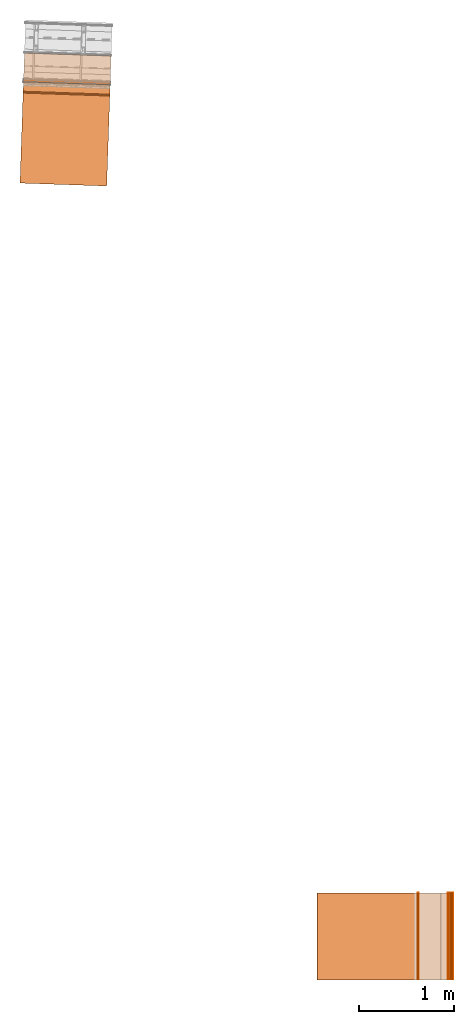
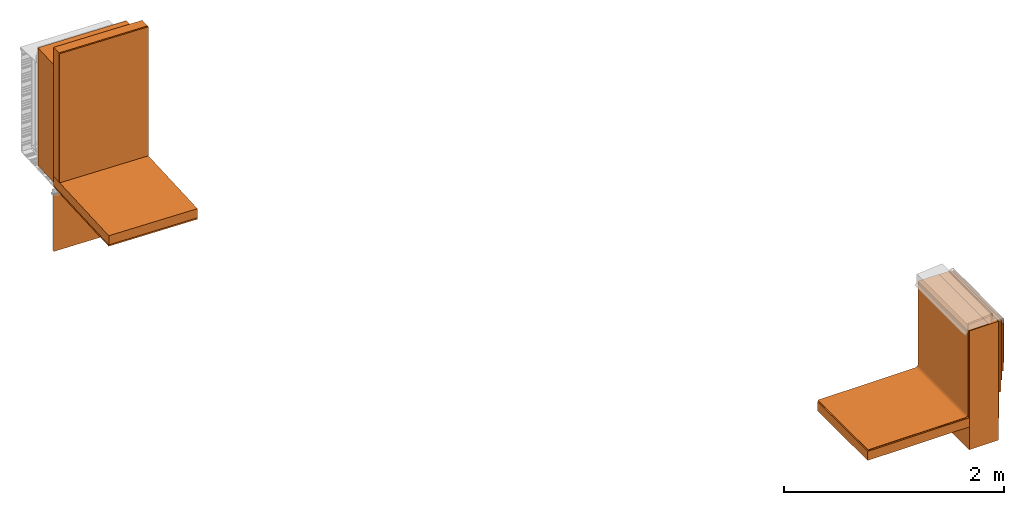
# One storey, part 1 of 6: 16 proxies.
"""IFC2X3 building model written with IfcOpenShell, lengths in feet."""

from ifc_helpers import new_model, entity, si_unit, converted_unit, derived_unit, direction, frame, frame_2d, origin, origin_2d_with_axis, place, context, subcontext, project, spatial, polyline, circle_curve, parameter, trimmed, segment, composite_curve, rectangle, outline, extrude, source, transform, mapped, material, type_object, type_shapes, element, save


model = new_model("IFC2X3")

# Units and contexts
model_context = context("Model", 3, precision=0.0001, world=origin(), true_north=direction((6.12303176911189e-17, 1.0)))
context_of_model = context(None, 3, precision=0.0001, world=origin(), true_north=direction((6.12303176911189e-17, 1.0)))
body_context = subcontext(model_context, "Body", "Model", "MODEL_VIEW")
ifc_project = project(units=[converted_unit("LENGTHUNIT", "FOOT", entity("IfcRatioMeasure", 0.3048), si_unit("LENGTHUNIT", "METRE"), dimensions=[1, 0, 0, 0, 0, 0, 0]), converted_unit("AREAUNIT", "SQUARE FOOT", entity("IfcRatioMeasure", 0.09290304), si_unit("AREAUNIT", "SQUARE_METRE"), dimensions=[2, 0, 0, 0, 0, 0, 0]), si_unit("VOLUMEUNIT", "CUBIC_METRE"), converted_unit("PLANEANGLEUNIT", "DEGREE", entity("IfcRatioMeasure", 0.0174532925199433), si_unit("PLANEANGLEUNIT", "RADIAN"), dimensions=[0, 0, 0, 0, 0, 0, 0]), si_unit("MASSUNIT", "GRAM", prefix="KILO"), derived_unit("MASSDENSITYUNIT", [(si_unit("MASSUNIT", "GRAM", prefix="KILO"), 1), (si_unit("LENGTHUNIT", "METRE"), -3)]), si_unit("TIMEUNIT", "SECOND"), si_unit("FREQUENCYUNIT", "HERTZ"), si_unit("THERMODYNAMICTEMPERATUREUNIT", "DEGREE_CELSIUS"), derived_unit("THERMALTRANSMITTANCEUNIT", [(si_unit("MASSUNIT", "GRAM", prefix="KILO"), 1), (si_unit("THERMODYNAMICTEMPERATUREUNIT", "KELVIN"), -1), (si_unit("TIMEUNIT", "SECOND"), -3)]), derived_unit("VOLUMETRICFLOWRATEUNIT", [(si_unit("LENGTHUNIT", "METRE"), 3), (si_unit("TIMEUNIT", "SECOND"), -1)]), si_unit("ELECTRICCURRENTUNIT", "AMPERE"), si_unit("ELECTRICVOLTAGEUNIT", "VOLT"), si_unit("POWERUNIT", "WATT"), si_unit("FORCEUNIT", "NEWTON"), si_unit("ILLUMINANCEUNIT", "LUX"), si_unit("LUMINOUSFLUXUNIT", "LUMEN"), si_unit("LUMINOUSINTENSITYUNIT", "CANDELA"), derived_unit("USERDEFINED", [(si_unit("MASSUNIT", "GRAM", prefix="KILO"), -1), (si_unit("LENGTHUNIT", "METRE"), -2), (si_unit("TIMEUNIT", "SECOND"), 3), (si_unit("LUMINOUSFLUXUNIT", "LUMEN"), 1)]), derived_unit("LINEARVELOCITYUNIT", [(si_unit("LENGTHUNIT", "METRE"), 1), (si_unit("TIMEUNIT", "SECOND"), -1)]), si_unit("PRESSUREUNIT", "PASCAL"), derived_unit("USERDEFINED", [(si_unit("LENGTHUNIT", "METRE"), -2), (si_unit("MASSUNIT", "GRAM", prefix="KILO"), 1), (si_unit("TIMEUNIT", "SECOND"), -2)])], contexts=[model_context, context_of_model])

# Site, building, storey
site_placement = place(None, origin())
site = spatial("IfcSite", under=ifc_project, at=site_placement, CompositionType="ELEMENT")
building_placement = place(site_placement, origin())
building = spatial("IfcBuilding", under=site, at=building_placement, CompositionType="ELEMENT")
storey_placement = place(building_placement, origin())
storey = spatial("IfcBuildingStorey", under=building, at=storey_placement, Name="Level 1", CompositionType="ELEMENT", Elevation=0.0)

# Proxies
ifc_material_1 = material()
building_element_proxy_type_1 = type_object("IfcBuildingElementProxyType", Name="Rigid insulation 002:Rigid insulation 002", PredefinedType="NOTDEFINED", material=ifc_material_1)
shared_shape_1 = source(origin(), body_context, "Body", "SweptSolid", [
    extrude(rectangle(XDim=3.50495130620078, YDim=2.99999999999999, at=frame_2d((0.0, 7.105427357601e-15), x_axis=(1.0, 0.0))), frame((121.624397761532, -80.1652000961286, 15.0), z_axis=(0.0, 0.0, 1.0), x_axis=(-1.0, 0.0, 0.0)), (0.0, 0.0, 1.0), 0.333333333333337),
])
type_shapes(building_element_proxy_type_1, [shared_shape_1])
proxy_1_placement = place(storey_placement, origin())
element("IfcBuildingElementProxy", 1, at=proxy_1_placement, inside=storey, type_object=building_element_proxy_type_1, material=ifc_material_1, context=body_context, shape_type="MappedRepresentation", body=[
    mapped(shared_shape_1, transform((0.0, 0.0, 0.0), scale=1.0)),
])
ifc_material_2 = material(Name="_EXISTING CAST-IN-PLACE CONCRETE")
building_element_proxy_type_2 = type_object("IfcBuildingElementProxyType", Name="Concrete wall 002:Concrete wall 002", PredefinedType="NOTDEFINED", material=ifc_material_2)
shared_shape_2 = source(origin(), body_context, "Body", "SweptSolid", [
    extrude(rectangle(XDim=0.999999999999972, YDim=2.99999999999999, at=frame_2d((1.4210854715202e-14, 7.105427357601e-15), x_axis=(1.0, 0.0))), frame((123.876873414633, -80.1652000961286, 14.1666666666667), z_axis=(0.0, 0.0, 1.0), x_axis=(-1.0, 0.0, 0.0)), (0.0, 0.0, 1.0), 4.33333333333333),
])
type_shapes(building_element_proxy_type_2, [shared_shape_2])
proxy_2_placement = place(storey_placement, origin())
element("IfcBuildingElementProxy", 2, at=proxy_2_placement, inside=storey, type_object=building_element_proxy_type_2, material=ifc_material_2, ObjectType="Concrete wall 002 : Concrete wall 002:Concrete wall 002", context=body_context, shape_type="MappedRepresentation", body=[
    mapped(shared_shape_2, transform((0.0, 0.0, 0.0), scale=1.0)),
])
ifc_material_3 = material(Name="IMPERMEABLE WRB MEMBRANE")
building_element_proxy_type_3 = type_object("IfcBuildingElementProxyType", Name="WRB Membrane 002:WRB Membrane 002", PredefinedType="NOTDEFINED", material=ifc_material_3)
shared_shape_3 = source(origin(), body_context, "Body", "SweptSolid", [
    extrude(rectangle(XDim=0.0208333335301916, YDim=3.0, at=origin_2d_with_axis()), frame((124.491456747933, -80.1652000961286, 16.3258133535433), z_axis=(0.0, 0.0, 1.0), x_axis=(-1.0, 0.0, 0.0)), (0.0, 0.0, 1.0), 2.17418664645669),
])
type_shapes(building_element_proxy_type_3, [shared_shape_3])
proxy_3_placement = place(storey_placement, origin())
element("IfcBuildingElementProxy", 3, at=proxy_3_placement, inside=storey, type_object=building_element_proxy_type_3, material=ifc_material_3, context=body_context, shape_type="MappedRepresentation", body=[
    mapped(shared_shape_3, transform((0.0, 0.0, 0.0), scale=1.0)),
])
building_element_proxy_type_4 = type_object("IfcBuildingElementProxyType", Name="Cement bond coat 002:Cement bond coat 002", PredefinedType="NOTDEFINED", material=ifc_material_3)
shared_shape_4 = source(origin(), body_context, "Body", "SweptSolid", [
    extrude(rectangle(XDim=0.0520833333333144, YDim=2.99999999999999, at=frame_2d((0.0, 7.105427357601e-15), x_axis=(1.0, 0.0))), frame((124.527915081496, -80.1652000961286, 16.6369885221785), z_axis=(0.0, 0.0, 1.0), x_axis=(-1.0, 0.0, 0.0)), (0.0, 0.0, 1.0), 1.7338879536868),
])
type_shapes(building_element_proxy_type_4, [shared_shape_4])
proxy_4_placement = place(storey_placement, origin())
element("IfcBuildingElementProxy", 4, at=proxy_4_placement, inside=storey, type_object=building_element_proxy_type_4, material=ifc_material_3, context=body_context, shape_type="MappedRepresentation", body=[
    mapped(shared_shape_4, transform((0.0, 0.0, 0.0), scale=1.0)),
])
ifc_material_4 = material(Name="PRESSURE TREATED WOOD BLOCKING - SIZE AS")
building_element_proxy_type_5 = type_object("IfcBuildingElementProxyType", Name="TPO Membrane 002:TPO Membrane 002", PredefinedType="NOTDEFINED", material=ifc_material_4)
shared_shape_5 = source(origin(), body_context, "Body", "SweptSolid", [
    extrude(outline(composite_curve([segment(polyline([(-1.27708333333181, -2.88937771162654), (-1.26666666666515, -2.88937771162654)]), True, "CONTINUOUS"), segment(polyline([(-1.26666666666515, -2.88937771162654), (-1.26666666666515, 0.469740261240503)]), True, "CONTINUOUS"), segment(trimmed(circle_curve(frame_2d((-1.17291666666664, 0.469740261240503), x_axis=(0.0, 1.0)), 0.0937499999969816), [parameter(6.18808718825542e-10)], [parameter(90.0000000000001)], True, "PARAMETER"), False, "CONTINUOUS"), segment(polyline([(-1.17291666666765, 0.56349026123749), (1.8635416666649, 0.563490261240887)]), True, "CONTINUOUS"), segment(polyline([(1.8635416666649, 0.563490261240887), (1.8635416666649, 1.28224026124093)]), True, "CONTINUOUS"), segment(polyline([(1.8635416666649, 1.28224026124093), (1.85312499999824, 1.28224026124093)]), True, "CONTINUOUS"), segment(polyline([(1.85312499999824, 1.28224026124093), (1.85312499999824, 0.573906927907572)]), True, "CONTINUOUS"), segment(polyline([(1.85312499999824, 0.573906927907572), (-1.17291666666777, 0.573906927874745)]), True, "CONTINUOUS"), segment(trimmed(circle_curve(frame_2d((-1.17291666666664, 0.469740261240503), x_axis=(0.0, 1.0)), 0.104166666663648), [parameter(6.21404051445617e-10)], [parameter(90.0000000000001)], True, "PARAMETER"), True, "CONTINUOUS"), segment(polyline([(-1.27708333333029, 0.469740261240503), (-1.27708333333181, -2.88937771162654)]), True, "CONTINUOUS")], self_intersect=False)), frame((122.771716486725, -81.6652000961286, 16.6520833333351), z_axis=(0.0, 1.0, 0.0), x_axis=(0.0, 0.0, 1.0)), (0.0, 0.0, 1.0), 3.0),
])
type_shapes(building_element_proxy_type_5, [shared_shape_5])
proxy_5_placement = place(storey_placement, origin())
element("IfcBuildingElementProxy", 5, at=proxy_5_placement, inside=storey, type_object=building_element_proxy_type_5, material=ifc_material_4, ObjectType="TPO Membrane 002 : TPO Membrane 002:TPO Membrane 002", context=body_context, shape_type="MappedRepresentation", body=[
    mapped(shared_shape_5, transform((0.0, 0.0, 0.0), scale=1.0)),
])
ifc_material_5 = material()
building_element_proxy_type_6 = type_object("IfcBuildingElementProxyType", Name="Scratch coat 002:Scratch coat 002", PredefinedType="NOTDEFINED", material=ifc_material_5)
shared_shape_6 = source(origin(), body_context, "Body", "SweptSolid", [
    extrude(rectangle(XDim=0.020833333333357, YDim=2.98958333333334, at=frame_2d((7.105427357601e-15, 0.0), x_axis=(1.0, 0.0))), frame((124.387290081168, -80.1599917627953, 15.5), z_axis=(0.0, 0.0, 1.0), x_axis=(-1.0, 0.0, 0.0)), (0.0, 0.0, 1.0), 3.0),
])
type_shapes(building_element_proxy_type_6, [shared_shape_6])
proxy_6_placement = place(storey_placement, origin())
element("IfcBuildingElementProxy", 6, at=proxy_6_placement, inside=storey, type_object=building_element_proxy_type_6, material=ifc_material_5, ObjectType="Scratch coat 002 : Scratch coat 002:Scratch coat 002", context=body_context, shape_type="MappedRepresentation", body=[
    mapped(shared_shape_6, transform((0.0, 0.0, 0.0), scale=1.0)),
])
ifc_material_6 = material(Name="(CT-01) PORCELAIN WALL TILE")
building_element_proxy_type_7 = type_object("IfcBuildingElementProxyType", Name="Porcelain tiles 002:Porcelain tiles 002", PredefinedType="NOTDEFINED", material=ifc_material_6)
shared_shape_7 = source(origin(), body_context, "Body", "SweptSolid", [
    extrude(rectangle(XDim=0.0208333333333144, YDim=1.0, at=origin_2d_with_axis()), frame((124.564373414816, -79.1652000961286, 16.9313125410105)), (0.0, 0.0, 1.0), 1.5686874589895),
    extrude(rectangle(XDim=0.0208333333333144, YDim=1.0, at=origin_2d_with_axis()), frame((124.564373414816, -80.1735334294619, 16.9313125410105)), (0.0, 0.0, 1.0), 1.5686874589895),
    extrude(rectangle(XDim=0.983333333333334, YDim=0.0208333333333144, at=frame_2d((-7.105427357601e-15, 0.0), x_axis=(1.0, 0.0))), frame((124.564373414816, -81.1735334294619, 16.9313125410105), z_axis=(0.0, 0.0, 1.0), x_axis=(0.0, -1.0, 0.0)), (0.0, 0.0, 1.0), 1.5686874589895),
])
type_shapes(building_element_proxy_type_7, [shared_shape_7])
proxy_7_placement = place(storey_placement, origin())
element("IfcBuildingElementProxy", 7, at=proxy_7_placement, inside=storey, type_object=building_element_proxy_type_7, material=ifc_material_6, context=body_context, shape_type="MappedRepresentation", body=[
    mapped(shared_shape_7, transform((0.0, 0.0, 0.0), scale=1.0)),
])
building_element_proxy_type_8 = type_object("IfcBuildingElementProxyType", Name="Metal lath 002:Metal lath 002", PredefinedType="NOTDEFINED", material=ifc_material_5)
shared_shape_8 = source(origin(), body_context, "Body", "SweptSolid", [
    extrude(rectangle(XDim=2.98958333333333, YDim=0.0164041994750477, at=frame_2d((7.105427357601e-15, 7.105427357601e-15), x_axis=(1.0, 0.0))), frame((124.405998558071, -80.1599917627953, 14.9586643008858), z_axis=(0.0, 0.0, 1.0), x_axis=(0.0, 1.0, 0.0)), (0.0, 0.0, 1.0), 3.54133569911417),
])
type_shapes(building_element_proxy_type_8, [shared_shape_8])
proxy_8_placement = place(storey_placement, origin())
element("IfcBuildingElementProxy", 8, at=proxy_8_placement, inside=storey, type_object=building_element_proxy_type_8, material=ifc_material_5, ObjectType="Metal lath 002 : Metal lath 002:Metal lath 002", context=body_context, shape_type="MappedRepresentation", body=[
    mapped(shared_shape_8, transform((0.0, 0.0, 0.0), scale=1.0)),
])
ifc_material_7 = material(Name="MORTAR BED")
building_element_proxy_type_9 = type_object("IfcBuildingElementProxyType", Name="Mortar bed 002:Mortar bed 002", PredefinedType="NOTDEFINED", material=ifc_material_7)
shared_shape_9 = source(origin(), body_context, "Body", "SweptSolid", [
    extrude(rectangle(XDim=2.98958333333333, YDim=0.0669291338582809, at=frame_2d((7.105427357601e-15, 0.0), x_axis=(1.0, 0.0))), frame((124.447575514239, -80.1599917627953, 15.8990862989173), z_axis=(0.0, 0.0, 1.0), x_axis=(0.0, 1.0, 0.0)), (0.0, 0.0, 1.0), 2.60091370108267),
])
type_shapes(building_element_proxy_type_9, [shared_shape_9])
proxy_9_placement = place(storey_placement, origin())
element("IfcBuildingElementProxy", 9, at=proxy_9_placement, inside=storey, type_object=building_element_proxy_type_9, material=ifc_material_7, ObjectType="Mortar bed 002 : Mortar bed 002:Mortar bed 002", context=body_context, shape_type="MappedRepresentation", body=[
    mapped(shared_shape_9, transform((0.0, 0.0, 0.0), scale=1.0)),
])
ifc_material_8 = material()
building_element_proxy_type_10 = type_object("IfcBuildingElementProxyType", Name="Mortar bed 1:Mortar bed 002", PredefinedType="NOTDEFINED", material=ifc_material_8)
shared_shape_10 = source(origin(), body_context, "Body", "SweptSolid", [
    extrude(rectangle(XDim=3.0, YDim=0.0208333333333712, at=origin_2d_with_axis()), frame((123.366456747966, -80.1652000961286, 15.3333333333333), z_axis=(0.0, 0.0, 1.0), x_axis=(0.0, 1.0, 0.0)), (0.0, 0.0, 1.0), 3.16666666666667),
])
type_shapes(building_element_proxy_type_10, [shared_shape_10])
proxy_10_placement = place(storey_placement, origin())
element("IfcBuildingElementProxy", 10, at=proxy_10_placement, inside=storey, type_object=building_element_proxy_type_10, material=ifc_material_8, ObjectType="Mortar bed 002 : Mortar bed 1:Mortar bed 002", context=body_context, shape_type="MappedRepresentation", body=[
    mapped(shared_shape_10, transform((0.0, 0.0, 0.0), scale=1.0)),
])
building_element_proxy_type_11 = type_object("IfcBuildingElementProxyType", Name="Concrete wall001", PredefinedType="NOTDEFINED", material=ifc_material_4)
shared_shape_11 = source(origin(), body_context, "Body", "SweptSolid", [
    extrude(rectangle(XDim=3.0, YDim=1.00000000008858, at=origin_2d_with_axis()), frame((111.232112399029, -50.1693051540586, 9.87499999999999), z_axis=(0.0, 0.0, 1.0), x_axis=(-0.999414947916633, 0.034201781836541, 0.0)), (0.0, 0.0, 1.0), 4.29166666666666),
])
type_shapes(building_element_proxy_type_11, [shared_shape_11])
proxy_11_placement = place(storey_placement, origin())
element("IfcBuildingElementProxy", 11, at=proxy_11_placement, inside=storey, type_object=building_element_proxy_type_11, material=ifc_material_4, Name="Concrete wall001:Concrete wall001", ObjectType="Concrete wall001", context=body_context, shape_type="MappedRepresentation", body=[
    mapped(shared_shape_11, transform((0.0, 0.0, 0.0), scale=1.0)),
])
ifc_material_9 = material(Name="Rigid insulation")
building_element_proxy_type_12 = type_object("IfcBuildingElementProxyType", Name="Insulation horizontal001", PredefinedType="NOTDEFINED", material=ifc_material_9)
shared_shape_12 = source(origin(), body_context, "Body", "SweptSolid", [
    extrude(rectangle(XDim=3.00000000000001, YDim=3.50495130610237, at=frame_2d((7.105427357601e-15, 2.22044604925031e-16), x_axis=(1.0, 0.0))), frame((111.15507371815, -52.4204629915805, 9.76041666666666), z_axis=(0.0, 0.0, 1.0), x_axis=(-0.999414947916632, 0.0342017818365576, 0.0)), (0.0, 0.0, 1.0), 0.333333333333334),
])
type_shapes(building_element_proxy_type_12, [shared_shape_12])
proxy_12_placement = place(storey_placement, origin())
element("IfcBuildingElementProxy", 12, at=proxy_12_placement, inside=storey, type_object=building_element_proxy_type_12, material=ifc_material_9, Name="Insulation horizontal001:Insulation horizontal001", ObjectType="Insulation horizontal001", context=body_context, shape_type="MappedRepresentation", body=[
    mapped(shared_shape_12, transform((0.0, 0.0, 0.0), scale=1.0)),
])
building_element_proxy_type_13 = type_object("IfcBuildingElementProxyType", Name="Insulation vertical001", PredefinedType="NOTDEFINED", material=ifc_material_9)
shared_shape_13 = source(origin(), body_context, "Body", "SweptSolid", [
    extrude(rectangle(XDim=2.99999999999999, YDim=0.333333333431769, at=frame_2d((7.105427357601e-15, 2.35922392732846e-16), x_axis=(1.0, 0.0))), frame((111.209311211139, -50.8355817859981, 10.09375), z_axis=(0.0, 0.0, 1.0), x_axis=(-0.999414947916632, 0.0342017818365767, 0.0)), (0.0, 0.0, 1.0), 4.7067749343832),
])
type_shapes(building_element_proxy_type_13, [shared_shape_13])
proxy_13_placement = place(storey_placement, origin())
element("IfcBuildingElementProxy", 13, at=proxy_13_placement, inside=storey, type_object=building_element_proxy_type_13, material=ifc_material_9, Name="Insulation vertical001:Insulation vertical001", ObjectType="Insulation vertical001", context=body_context, shape_type="MappedRepresentation", body=[
    mapped(shared_shape_13, transform((0.0, 0.0, 0.0), scale=1.0)),
])
building_element_proxy_type_14 = type_object("IfcBuildingElementProxyType", Name="Inner gypsum board001", PredefinedType="NOTDEFINED", material=ifc_material_4)
shared_shape_14 = source(origin(), body_context, "Body", "SweptSolid", [
    extrude(rectangle(XDim=3.00000000000001, YDim=0.0520833333333173, at=frame_2d((1.11022302462516e-16, -3.55097895532452e-15), x_axis=(1.0, 0.0))), frame((111.202720242762, -51.0281773749685, 10.09375), z_axis=(0.0, 0.0, 1.0), x_axis=(-0.999414947916637, 0.0342017818364297, 0.0)), (0.0, 0.0, 1.0), 4.7067749343832),
])
type_shapes(building_element_proxy_type_14, [shared_shape_14])
proxy_14_placement = place(storey_placement, origin())
element("IfcBuildingElementProxy", 14, at=proxy_14_placement, inside=storey, type_object=building_element_proxy_type_14, material=ifc_material_4, Name="Inner gypsum board001:Inner gypsum board001", ObjectType="Inner gypsum board001", context=body_context, shape_type="MappedRepresentation", body=[
    mapped(shared_shape_14, transform((0.0, 0.0, 0.0), scale=1.0)),
])
building_element_proxy_type_15 = type_object("IfcBuildingElementProxyType", Name="Inner ceiling001", PredefinedType="NOTDEFINED", material=ifc_material_4)
shared_shape_15 = source(origin(), body_context, "Body", "SweptSolid", [
    extrude(rectangle(XDim=3.0, YDim=3.50495130633201, at=frame_2d((7.105427357601e-15, 2.22044604925031e-16), x_axis=(1.0, 0.0))), frame((111.155073718154, -52.4204629914657, 9.70833333333332), z_axis=(0.0, 0.0, 1.0), x_axis=(-0.999414947916632, 0.0342017818365529, 0.0)), (0.0, 0.0, 1.0), 0.0520833333333339),
])
type_shapes(building_element_proxy_type_15, [shared_shape_15])
proxy_15_placement = place(storey_placement, origin())
element("IfcBuildingElementProxy", 15, at=proxy_15_placement, inside=storey, type_object=building_element_proxy_type_15, material=ifc_material_4, Name="Inner ceiling001:Inner ceiling001", ObjectType="Inner ceiling001", context=body_context, shape_type="MappedRepresentation", body=[
    mapped(shared_shape_15, transform((0.0, 0.0, 0.0), scale=1.0)),
])
ifc_material_10 = material(Name="Clear glass")
building_element_proxy_type_16 = type_object("IfcBuildingElementProxyType", Name="Glass panel 004", PredefinedType="NOTDEFINED", material=ifc_material_10)
shared_shape_16 = source(origin(), body_context, "Body", "SweptSolid", [
    extrude(rectangle(XDim=3.0, YDim=0.0156250000000211, at=origin_2d_with_axis()), frame((111.2150071805, -50.6691390856077, 7.3556443373819), z_axis=(0.0, 0.0, 1.0), x_axis=(-0.999414947916663, 0.0342017818356435, 0.0)), (0.0, 0.0, 1.0), 2.094323495),
])
type_shapes(building_element_proxy_type_16, [shared_shape_16])
proxy_16_placement = place(storey_placement, origin())
element("IfcBuildingElementProxy", 16, at=proxy_16_placement, inside=storey, type_object=building_element_proxy_type_16, material=ifc_material_10, Name="Glass panel 004:Glass panel 004", ObjectType="Glass panel 004", context=body_context, shape_type="MappedRepresentation", body=[
    mapped(shared_shape_16, transform((0.0, 0.0, 0.0), scale=1.0)),
])

save(model, "model.ifc")
